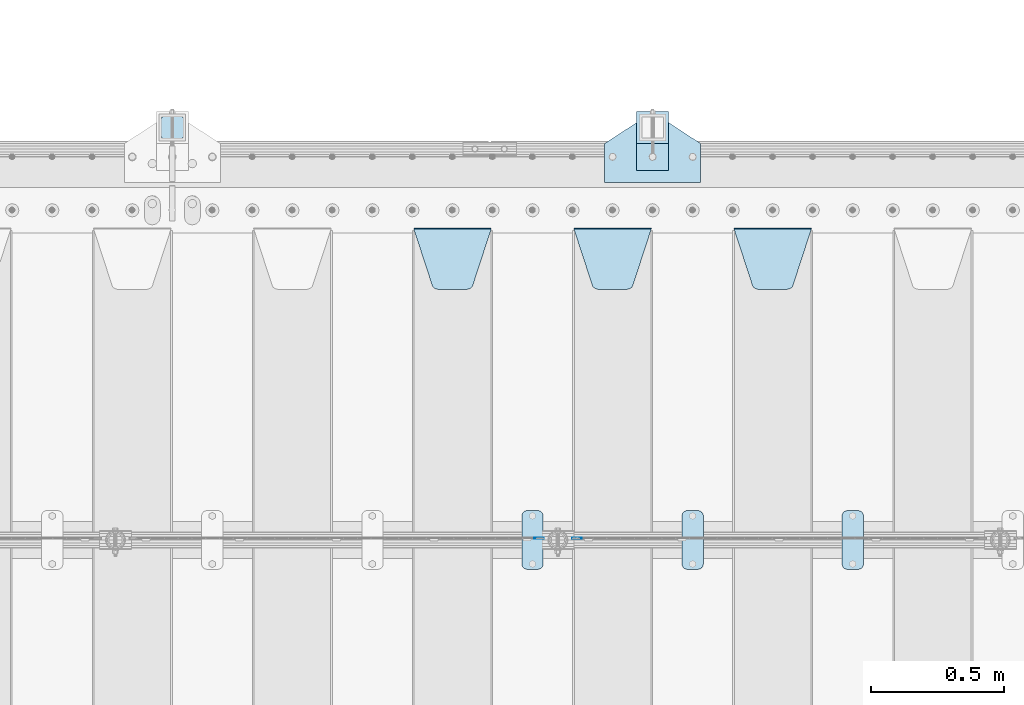
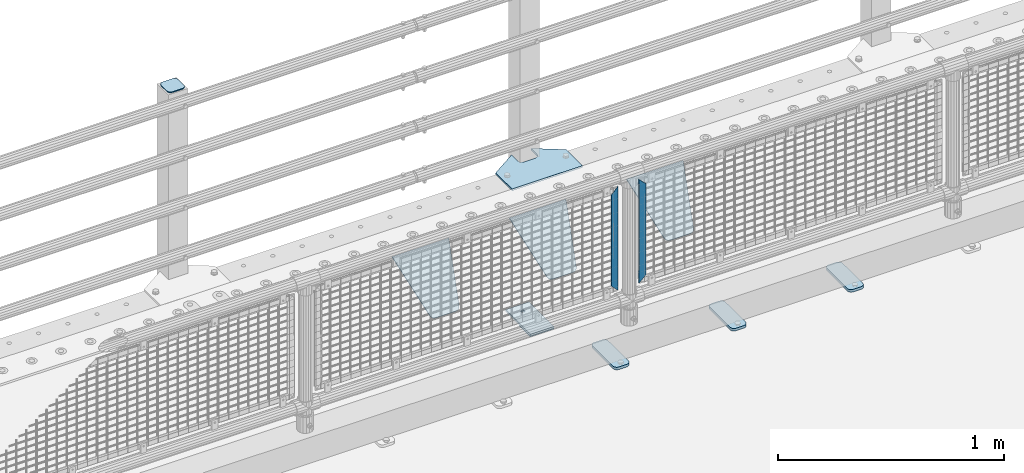
# One storey, part 197 of 219: 12 plates.
"""IFC2X3 building model written with IfcOpenShell, lengths in millimetres."""

import ifcopenshell
import ifcopenshell.guid

model = None  # the IFC model being written
_history = None  # IfcOwnerHistory: only IFC2X3 demands one
_inside = {}  # id of a spatial element -> (the spatial element, [elements in it])
_under = {}  # id of a project, library or spatial element -> (it, [spatial elements below it])
_declared = {}  # id of a project -> (the project, [libraries it declares])
_typed = {}  # id of a type object -> (the type object, [elements of that type])
_made_of = {}  # id of a material, layer set ... -> (it, [elements and type objects made of it])


def new_model(schema):
    """Start an empty IFC model of exactly this schema.

    Asked for "IFC4X3", IfcOpenShell would pick the latest addendum, in which some entities
    have other attributes; the version numbers below select the first issue.
    IFC2X3 requires an IfcOwnerHistory on every rooted entity: one is made here for all.
    """
    global model, _history
    if schema == "IFC4X3":
        model = ifcopenshell.file(schema_version=(4, 3, 0, 0))
    else:
        model = ifcopenshell.file(schema=schema)
    _inside.clear()
    _under.clear()
    _declared.clear()
    _typed.clear()
    _made_of.clear()
    _history = None
    if model.schema == "IFC2X3":
        org = make("IfcOrganization", Name="unknown")
        user = make(
            "IfcPersonAndOrganization",
            ThePerson=make("IfcPerson", FamilyName="unknown"),
            TheOrganization=org,
        )
        app = make(
            "IfcApplication",
            ApplicationDeveloper=org,
            Version="unknown",
            ApplicationFullName="unknown",
            ApplicationIdentifier="unknown",
        )
        _history = make(
            "IfcOwnerHistory",
            OwningUser=user,
            OwningApplication=app,
            ChangeAction="ADDED",
            CreationDate=0,
        )
    return model


def make(cls, **values):
    """One entity of the class cls with the attributes given. An attribute that is None is left unset."""
    return model.create_entity(
        cls, **{name: value for name, value in values.items() if value is not None}
    )


def rooted(cls, **values):
    """An entity with a GlobalId (a new one), such as an element, a storey or a relation."""
    return make(cls, GlobalId=ifcopenshell.guid.new(), OwnerHistory=_history, **values)


def si_unit(unit_type, name, prefix=None):
    """IfcSIUnit, for example si_unit("LENGTHUNIT", "METRE", prefix="MILLI")."""
    return make("IfcSIUnit", UnitType=unit_type, Prefix=prefix, Name=name)


def assignment(units):
    """IfcUnitAssignment: the units of a project."""
    return None if units is None else make("IfcUnitAssignment", Units=units)


def point(xyz):
    """IfcCartesianPoint."""
    return None if xyz is None else make("IfcCartesianPoint", Coordinates=xyz)


def direction(xyz):
    """IfcDirection."""
    return None if xyz is None else make("IfcDirection", DirectionRatios=xyz)


def frame(location, z_axis=None, x_axis=None):
    """IfcAxis2Placement3D, a coordinate frame: its origin and axes. An axis left out is left unset."""
    return make(
        "IfcAxis2Placement3D",
        Location=point(location),
        Axis=direction(z_axis),
        RefDirection=direction(x_axis),
    )


def origin_with_axes():
    """The frame at (0, 0, 0) with the z axis (0, 0, 1) and the x axis (1, 0, 0) written out."""
    return frame((0.0, 0.0, 0.0), z_axis=(0.0, 0.0, 1.0), x_axis=(1.0, 0.0, 0.0))


def place(relative_to, where):
    """IfcLocalPlacement: puts the frame where relative to a parent placement (None: the world)."""
    return make(
        "IfcLocalPlacement", PlacementRelTo=relative_to, RelativePlacement=where
    )


def context(
    kind, dimensions, precision=None, world=None, true_north=None, identifier=None
):
    """IfcGeometricRepresentationContext, for example the 3D "Model" context."""
    return make(
        "IfcGeometricRepresentationContext",
        ContextIdentifier=identifier,
        ContextType=kind,
        CoordinateSpaceDimension=dimensions,
        Precision=precision,
        WorldCoordinateSystem=world,
        TrueNorth=true_north,
    )


def subcontext(parent, identifier, kind, view, scale=None):
    """IfcGeometricRepresentationSubContext, for example "Body" below "Model"."""
    return make(
        "IfcGeometricRepresentationSubContext",
        ContextIdentifier=identifier,
        ContextType=kind,
        ParentContext=parent,
        TargetScale=scale,
        TargetView=view,
    )


def project(units=None, contexts=None):
    """IfcProject with its units and contexts."""
    return rooted(
        "IfcProject",
        Name="project",
        RepresentationContexts=contexts,
        UnitsInContext=assignment(units),
    )


def spatial(cls, under=None, at=None, **own):
    """A site, building, storey or space (cls), placed at a placement, below another one or the project."""
    s = rooted(cls, ObjectPlacement=at, **own)
    if under is not None:
        _under.setdefault(under.id(), (under, []))[1].append(s)
    return s


def faces_of(points, faces, orient=None, outer=None):
    """IfcFace entities. A face is a list of loops; a loop is a list of indices into points, from 0.

    orient and outer hold one flag for each loop. By default every Orientation is true, the
    first loop of a face is its IfcFaceOuterBound and the others are IfcFaceBound.
    """
    made = []
    for i, loops in enumerate(faces):
        bounds = []
        for j, loop in enumerate(loops):
            is_outer = j == 0 if outer is None else outer[i][j]
            bounds.append(
                make(
                    "IfcFaceOuterBound" if is_outer else "IfcFaceBound",
                    Bound=make("IfcPolyLoop", Polygon=[points[k] for k in loop]),
                    Orientation=True if orient is None else orient[i][j],
                )
            )
        made.append(make("IfcFace", Bounds=bounds))
    return made


def faceted_brep(points, faces, orient=None, outer=None, voids=None):
    """IfcFacetedBrep: a solid bounded by flat faces; with voids (closed shells), ...WithVoids."""
    shared = [point(p) for p in points]
    hull = make("IfcClosedShell", CfsFaces=faces_of(shared, faces, orient, outer))
    if voids is None:
        return make("IfcFacetedBrep", Outer=hull)
    return make(
        "IfcFacetedBrepWithVoids",
        Outer=hull,
        Voids=[
            make(cls, CfsFaces=faces_of(shared, fs, o, b)) for cls, fs, o, b in voids
        ],
    )


def shape(context_of_items, identifier, shape_type, items):
    """IfcShapeRepresentation: the items that make up one representation, for example the "Body"."""
    return make(
        "IfcShapeRepresentation",
        ContextOfItems=context_of_items,
        RepresentationIdentifier=identifier,
        RepresentationType=shape_type,
        Items=items,
    )


def material(Name=None, Category=None):
    """IfcMaterial."""
    return make("IfcMaterial", Name=Name, Category=Category)


def made_of(thing, what):
    """Note that an element or type object is made of a material, layer set ...; save() writes the relation."""
    if what is not None:
        _made_of.setdefault(what.id(), (what, []))[1].append(thing)
    return thing


def type_object(cls, material=None, **own):
    """A type object (cls), such as IfcWallType, which elements share."""
    return made_of(rooted(cls, **own), material)


def element(
    cls,
    number,
    at=None,
    inside=None,
    cuts=None,
    type_object=None,
    material=None,
    context=None,
    identifier="Body",
    shape_type=None,
    held_by="IfcProductDefinitionShape",
    body=None,
    shapes=None,
    **own,
):
    """One element of the class cls, such as IfcWall. Its Tag is "e" and its number.

    at: its placement. inside: the storey or other place that contains it. cuts: it is an
    opening in that element (IfcRelVoidsElement). A single representation is given by context,
    identifier, shape_type and body (its items); several are given by shapes. held_by: the class
    of the entity that holds the representations. save() writes the other relations.
    """
    e = rooted(cls, Tag="e%d" % number, ObjectPlacement=at, **own)
    if body is not None:
        shapes = [shape(context, identifier, shape_type, body)]
    if shapes is not None:
        e.Representation = make(held_by, Representations=shapes)
    if inside is not None:
        _inside.setdefault(inside.id(), (inside, []))[1].append(e)
    if cuts is not None:
        rooted(
            "IfcRelVoidsElement", RelatingBuildingElement=cuts, RelatedOpeningElement=e
        )
    if type_object is not None:
        _typed.setdefault(type_object.id(), (type_object, []))[1].append(e)
    return made_of(e, material)


def aggregate(whole, parts):
    """IfcRelAggregates: a whole, such as a stair, and the parts it consists of."""
    return rooted("IfcRelAggregates", RelatingObject=whole, RelatedObjects=parts)


def save(model, path):
    """Write the relations noted so far, then the file.

    IfcRelAggregates (storeys below a building ...), IfcRelContainedInSpatialStructure (elements
    in a storey), IfcRelDefinesByType, IfcRelAssociatesMaterial and IfcRelDeclares: one each for
    every whole, place, type object, material and project.
    """
    for whole, parts in _under.values():
        aggregate(whole, parts)
    for where, things in _inside.values():
        rooted(
            "IfcRelContainedInSpatialStructure",
            RelatedElements=things,
            RelatingStructure=where,
        )
    for kind, things in _typed.values():
        rooted("IfcRelDefinesByType", RelatedObjects=things, RelatingType=kind)
    for what, things in _made_of.values():
        rooted("IfcRelAssociatesMaterial", RelatedObjects=things, RelatingMaterial=what)
    for by, libraries in _declared.values():
        rooted("IfcRelDeclares", RelatingContext=by, RelatedDefinitions=libraries)
    model.write(path)


model = new_model("IFC2X3")

# Units and contexts
model_context = context("Model", 3, precision=1e-05, world=origin_with_axes())
body_context = subcontext(model_context, "Body", "Model", "MODEL_VIEW")
ifc_project = project(units=[si_unit("LENGTHUNIT", "METRE", prefix="MILLI"), si_unit("AREAUNIT", "SQUARE_METRE"), si_unit("VOLUMEUNIT", "CUBIC_METRE"), si_unit("MASSUNIT", "GRAM", prefix="KILO"), si_unit("TIMEUNIT", "SECOND"), si_unit("PLANEANGLEUNIT", "RADIAN"), si_unit("SOLIDANGLEUNIT", "STERADIAN"), si_unit("THERMODYNAMICTEMPERATUREUNIT", "DEGREE_CELSIUS"), si_unit("LUMINOUSINTENSITYUNIT", "LUMEN")], contexts=[model_context])

# Site, building, storey
site_placement = place(None, origin_with_axes())
site = spatial("IfcSite", under=ifc_project, at=site_placement, CompositionType="ELEMENT")
building_placement = place(site_placement, origin_with_axes())
building = spatial("IfcBuilding", under=site, at=building_placement, Name="Standard", CompositionType="ELEMENT")
storey_placement = place(building_placement, origin_with_axes())
storey = spatial("IfcBuildingStorey", under=building, at=storey_placement, Name="Undefined", CompositionType="ELEMENT", Elevation=0.0)

# Plates
ifc_material_1 = material(Name="STEEL/S355N")
plate_type_1 = type_object("IfcPlateType", PredefinedType="NOTDEFINED")
plate_1_placement = place(storey_placement, frame((6255.0, 32831.767766956, -1.76776695296758), z_axis=(0.0, -0.707106781186547, -0.707106781186548), x_axis=(1.0, 0.0, 0.0)))
element("IfcPlate", 1, at=plate_1_placement, inside=storey, type_object=plate_type_1, material=ifc_material_1, context=body_context, shape_type="Brep", body=[
    faceted_brep([(0.0, -2.5, 0.0), (69.345504679477, -2.5, 300.171731424834), (69.345504679477, 2.49999999999636, 300.171731424831), (0.0, 2.5, 0.0), (70.9274061199576, -2.50000000000364, 304.8974424154), (70.9274061199576, 2.49999999999636, 304.8974424154), (73.3818627772307, -2.50000000000364, 309.234538108532), (73.3818627772307, 2.49999999999636, 309.234538108532), (76.6187032999569, -2.50000000000364, 313.023683126106), (76.6187032999569, 2.49999999999636, 313.023683126106), (80.5190132704993, -2.50000000000364, 316.125672595372), (80.5190132704993, 2.49999999999636, 316.125672595372), (84.9395038596831, -2.50000000000364, 318.426546230476), (84.9395038596831, 2.5, 318.426546230479), (89.7177759439237, -2.50000000000364, 319.841774983277), (89.7177759439237, 2.5, 319.841774983281), (94.6782862926502, -2.50000000000364, 320.319366455078), (94.6782862926502, 2.49999999999636, 320.319366455078), (195.32171370735, -2.50000000000364, 320.319366455078), (195.32171370735, 2.49999999999636, 320.319366455078), (200.282224056076, -2.50000000000364, 319.841774983277), (200.282224056076, 2.5, 319.841774983281), (205.060496140317, -2.50000000000364, 318.426546230476), (205.060496140317, 2.49999999999636, 318.426546230476), (209.480986729501, -2.50000000000364, 316.125672595372), (209.480986729501, 2.49999999999636, 316.125672595372), (213.381296700043, -2.50000000000364, 313.023683126106), (213.381296700043, 2.49999999999272, 313.023683126106), (216.618137222769, -2.50000000000364, 309.234538108529), (216.618137222769, 2.49999999999636, 309.234538108525), (219.072593880042, -2.50000000000364, 304.8974424154), (219.072593880042, 2.49999999999636, 304.8974424154), (220.654495320523, -2.5, 300.171731424834), (220.654495320523, 2.49999999999636, 300.171731424831), (290.0, -2.50000000000364, 3.63797880709171e-12), (290.0, 2.49999999999636, 0.0)], [[[0, 1, 2, 3]], [[1, 4, 5, 2]], [[4, 6, 7, 5]], [[6, 8, 9, 7]], [[8, 10, 11, 9]], [[10, 12, 13, 11]], [[12, 14, 15, 13]], [[14, 16, 17, 15]], [[16, 18, 19, 17]], [[18, 20, 21, 19]], [[20, 22, 23, 21]], [[22, 24, 25, 23]], [[24, 26, 27, 25]], [[26, 28, 29, 27]], [[28, 30, 31, 29]], [[30, 32, 33, 31]], [[32, 34, 35, 33]], [[34, 0, 3, 35]], [[5, 7, 9, 11, 13, 15, 17, 19, 21, 23, 25, 27, 29, 31, 33, 35, 3, 2]], [[34, 32, 30, 28, 26, 24, 22, 20, 18, 16, 14, 12, 10, 8, 6, 4, 1, 0]]]),
])
plate_2_placement = place(storey_placement, frame((5655.0, 32831.767766956, -1.76776695296758), z_axis=(0.0, -0.707106781186547, -0.707106781186548), x_axis=(1.0, 0.0, 0.0)))
element("IfcPlate", 2, at=plate_2_placement, inside=storey, type_object=plate_type_1, material=ifc_material_1, context=body_context, shape_type="Brep", body=[
    faceted_brep([(0.0, -2.5, 0.0), (69.345504679477, -2.5, 300.171731424834), (69.345504679477, 2.49999999999636, 300.171731424831), (0.0, 2.5, 0.0), (70.9274061199576, -2.50000000000364, 304.8974424154), (70.9274061199576, 2.49999999999636, 304.8974424154), (73.3818627772307, -2.50000000000364, 309.234538108532), (73.3818627772307, 2.49999999999636, 309.234538108532), (76.6187032999569, -2.50000000000364, 313.023683126106), (76.6187032999569, 2.49999999999636, 313.023683126106), (80.5190132704993, -2.50000000000364, 316.125672595372), (80.5190132704993, 2.49999999999636, 316.125672595372), (84.9395038596831, -2.50000000000364, 318.426546230476), (84.9395038596831, 2.5, 318.426546230479), (89.7177759439237, -2.50000000000364, 319.841774983277), (89.7177759439237, 2.5, 319.841774983281), (94.6782862926502, -2.50000000000364, 320.319366455078), (94.6782862926502, 2.49999999999636, 320.319366455078), (195.32171370735, -2.50000000000364, 320.319366455078), (195.32171370735, 2.49999999999636, 320.319366455078), (200.282224056076, -2.50000000000364, 319.841774983277), (200.282224056076, 2.5, 319.841774983281), (205.060496140317, -2.50000000000364, 318.426546230476), (205.060496140317, 2.49999999999636, 318.426546230476), (209.480986729501, -2.50000000000364, 316.125672595372), (209.480986729501, 2.49999999999636, 316.125672595372), (213.381296700043, -2.50000000000364, 313.023683126106), (213.381296700043, 2.49999999999272, 313.023683126106), (216.618137222769, -2.50000000000364, 309.234538108529), (216.618137222769, 2.49999999999636, 309.234538108525), (219.072593880042, -2.50000000000364, 304.8974424154), (219.072593880042, 2.49999999999636, 304.8974424154), (220.654495320523, -2.5, 300.171731424834), (220.654495320523, 2.49999999999636, 300.171731424831), (290.0, -2.50000000000364, 3.63797880709171e-12), (290.0, 2.49999999999636, 0.0)], [[[0, 1, 2, 3]], [[1, 4, 5, 2]], [[4, 6, 7, 5]], [[6, 8, 9, 7]], [[8, 10, 11, 9]], [[10, 12, 13, 11]], [[12, 14, 15, 13]], [[14, 16, 17, 15]], [[16, 18, 19, 17]], [[18, 20, 21, 19]], [[20, 22, 23, 21]], [[22, 24, 25, 23]], [[24, 26, 27, 25]], [[26, 28, 29, 27]], [[28, 30, 31, 29]], [[30, 32, 33, 31]], [[32, 34, 35, 33]], [[34, 0, 3, 35]], [[5, 7, 9, 11, 13, 15, 17, 19, 21, 23, 25, 27, 29, 31, 33, 35, 3, 2]], [[34, 32, 30, 28, 26, 24, 22, 20, 18, 16, 14, 12, 10, 8, 6, 4, 1, 0]]]),
])
plate_3_placement = place(storey_placement, frame((5055.0, 32831.767766956, -1.76776695296758), z_axis=(0.0, -0.707106781186547, -0.707106781186548), x_axis=(1.0, 0.0, 0.0)))
element("IfcPlate", 3, at=plate_3_placement, inside=storey, type_object=plate_type_1, material=ifc_material_1, context=body_context, shape_type="Brep", body=[
    faceted_brep([(0.0, -2.5, 0.0), (69.345504679477, -2.5, 300.171731424834), (69.345504679477, 2.49999999999636, 300.171731424831), (0.0, 2.5, 0.0), (70.9274061199576, -2.50000000000364, 304.8974424154), (70.9274061199576, 2.49999999999636, 304.8974424154), (73.3818627772307, -2.50000000000364, 309.234538108532), (73.3818627772307, 2.49999999999636, 309.234538108532), (76.6187032999569, -2.50000000000364, 313.023683126106), (76.6187032999569, 2.49999999999636, 313.023683126106), (80.5190132704993, -2.50000000000364, 316.125672595372), (80.5190132704993, 2.49999999999636, 316.125672595372), (84.9395038596831, -2.50000000000364, 318.426546230476), (84.9395038596831, 2.5, 318.426546230479), (89.7177759439237, -2.50000000000364, 319.841774983277), (89.7177759439237, 2.5, 319.841774983281), (94.6782862926502, -2.50000000000364, 320.319366455078), (94.6782862926502, 2.49999999999636, 320.319366455078), (195.32171370735, -2.50000000000364, 320.319366455078), (195.32171370735, 2.49999999999636, 320.319366455078), (200.282224056076, -2.50000000000364, 319.841774983277), (200.282224056076, 2.5, 319.841774983281), (205.060496140317, -2.50000000000364, 318.426546230476), (205.060496140317, 2.49999999999636, 318.426546230476), (209.480986729501, -2.50000000000364, 316.125672595372), (209.480986729501, 2.49999999999636, 316.125672595372), (213.381296700043, -2.50000000000364, 313.023683126106), (213.381296700043, 2.49999999999272, 313.023683126106), (216.618137222769, -2.50000000000364, 309.234538108529), (216.618137222769, 2.49999999999636, 309.234538108525), (219.072593880042, -2.50000000000364, 304.8974424154), (219.072593880042, 2.49999999999636, 304.8974424154), (220.654495320523, -2.5, 300.171731424834), (220.654495320523, 2.49999999999636, 300.171731424831), (290.0, -2.50000000000364, 3.63797880709171e-12), (290.0, 2.49999999999636, 0.0)], [[[0, 1, 2, 3]], [[1, 4, 5, 2]], [[4, 6, 7, 5]], [[6, 8, 9, 7]], [[8, 10, 11, 9]], [[10, 12, 13, 11]], [[12, 14, 15, 13]], [[14, 16, 17, 15]], [[16, 18, 19, 17]], [[18, 20, 21, 19]], [[20, 22, 23, 21]], [[22, 24, 25, 23]], [[24, 26, 27, 25]], [[26, 28, 29, 27]], [[28, 30, 31, 29]], [[30, 32, 33, 31]], [[32, 34, 35, 33]], [[34, 0, 3, 35]], [[5, 7, 9, 11, 13, 15, 17, 19, 21, 23, 25, 27, 29, 31, 33, 35, 3, 2]], [[34, 32, 30, 28, 26, 24, 22, 20, 18, 16, 14, 12, 10, 8, 6, 4, 1, 0]]]),
])
ifc_material_2 = material(Name="Misc_Undefined")
plate_type_2 = type_object("IfcPlateType", PredefinedType="NOTDEFINED")
plate_4_placement = place(storey_placement, frame((5683.50971354097, 31670.5, 879.519963133601), z_axis=(-0.707008801899319, 0.0, -0.707204746899291), x_axis=(-0.707204746899285, 0.0, 0.707008801899324)))
element("IfcPlate", 4, at=plate_4_placement, inside=storey, type_object=plate_type_2, material=ifc_material_2, context=body_context, shape_type="Brep", body=[
    faceted_brep([(0.0, -1.5, -5.6843418860808e-14), (-348.552185058593, -1.5, 348.655029296875), (-348.552185058593, 1.5, 348.655029296875), (0.0, 1.5, -5.6843418860808e-14), (-348.544891357421, -1.5, 398.152496337892), (-348.544891357421, 1.5, 398.152496337892), (49.5043945312482, -1.5, 7.6397554948926e-11), (49.5043945312482, 1.5, 7.6397554948926e-11)], [[[0, 1, 2, 3]], [[1, 4, 5, 2]], [[4, 6, 7, 5]], [[6, 0, 3, 7]], [[5, 7, 3, 2]], [[6, 4, 1, 0]]]),
])
plate_5_placement = place(storey_placement, frame((5506.49968748361, 31670.5, 879.52), z_axis=(0.707103624179499, 0.0, -0.707109938179501), x_axis=(0.707109938179499, 0.0, 0.707103624179502)))
element("IfcPlate", 5, at=plate_5_placement, inside=storey, type_object=plate_type_2, material=ifc_material_2, context=body_context, shape_type="Brep", body=[
    faceted_brep([(0.0, -1.5, -5.6843418860808e-14), (-348.605163574219, -1.5, 348.602081298829), (-348.605163574219, 1.5, 348.602081298829), (0.0, 1.5, -5.6843418860808e-14), (-348.605163574217, -1.5, 398.0993347168), (-348.605163574217, 1.5, 398.0993347168), (49.4976959228516, -1.5, -1.0550138540566e-10), (49.4976959228516, 1.5, -1.0550138540566e-10)], [[[0, 1, 2, 3]], [[1, 4, 5, 2]], [[4, 6, 7, 5]], [[6, 0, 3, 7]], [[5, 7, 3, 2]], [[6, 4, 1, 0]]]),
])
ifc_material_3 = material(Name="STEEL/S355J2")
plate_type_3 = type_object("IfcPlateType", PredefinedType="NOTDEFINED")
plate_6_placement = place(storey_placement, frame((6660.0, 31774.5, 21.0199999999977), z_axis=(1.0, 0.0, 0.0), x_axis=(0.0, -1.0, 0.0)))
element("IfcPlate", 6, at=plate_6_placement, inside=storey, type_object=plate_type_3, material=ifc_material_3, context=body_context, shape_type="Brep", body=[
    faceted_brep([(0.0, -7.0, 20.0), (0.0, -7.0, 60.0), (0.0, 7.0, 60.0), (0.0, 7.0, 20.0), (0.384294391937146, -7.0, 63.9018064403226), (0.384294391937146, 7.0, 63.9018064403226), (1.52240934977453, -7.0, 67.6536686473009), (1.52240934977453, 7.0, 67.6536686473009), (3.37060775395003, -7.0, 71.1114046603925), (3.37060775395003, 7.0, 71.1114046603925), (5.8578643762703, -7.0, 74.1421356237315), (5.8578643762703, 7.0, 74.1421356237315), (8.88859533960931, -7.0, 76.6293922460518), (8.88859533960931, 7.0, 76.6293922460518), (12.3463313526991, -7.0, 78.4775906502255), (12.3463313526991, 7.0, 78.4775906502255), (16.0981935596792, -7.0, 79.6157056080647), (16.0981935596792, 7.0, 79.6157056080647), (20.0, -7.0, 80.0), (20.0, 7.0, 80.0), (200.0, -7.0, 80.0), (200.0, 7.0, 80.0), (203.901806440321, -7.0, 79.6157056080647), (203.901806440321, 7.0, 79.6157056080647), (207.653668647301, -7.0, 78.4775906502255), (207.653668647301, 7.0, 78.4775906502255), (211.111404660391, -7.0, 76.6293922460518), (211.111404660391, 7.0, 76.6293922460518), (214.14213562373, -7.0, 74.1421356237315), (214.14213562373, 7.0, 74.1421356237315), (216.62939224605, -7.0, 71.1114046603925), (216.62939224605, 7.0, 71.1114046603925), (218.477590650225, -7.0, 67.6536686473009), (218.477590650225, 7.0, 67.6536686473009), (219.615705608063, -7.0, 63.9018064403226), (219.615705608063, 7.0, 63.9018064403226), (220.0, -7.0, 60.0), (220.0, 7.0, 60.0), (220.0, -7.0, 20.0), (220.0, 7.0, 20.0), (219.615705608063, -7.0, 16.0981935596774), (219.615705608063, 7.0, 16.0981935596774), (218.477590650225, -7.0, 12.3463313526991), (218.477590650225, 7.0, 12.3463313526991), (216.62939224605, -7.0, 8.88859533960749), (216.62939224605, 7.0, 8.88859533960749), (214.14213562373, -7.0, 5.85786437626848), (214.14213562373, 7.0, 5.85786437626848), (211.111404660391, -7.0, 3.37060775394821), (211.111404660391, 7.0, 3.37060775394821), (207.653668647301, -7.0, 1.52240934977453), (207.653668647301, 7.0, 1.52240934977453), (203.901806440321, -7.0, 0.384294391935327), (203.901806440321, 7.0, 0.384294391935327), (200.0, -7.0, 0.0), (200.0, 7.0, 0.0), (20.0, -7.0, 0.0), (20.0, 7.0, 0.0), (16.0981935596792, -7.0, 0.384294391935327), (16.0981935596792, 7.0, 0.384294391935327), (12.3463313526991, -7.0, 1.52240934977453), (12.3463313526991, 7.0, 1.52240934977453), (8.88859533960931, -7.0, 3.37060775394821), (8.88859533960931, 7.0, 3.37060775394821), (5.8578643762703, -7.0, 5.85786437626848), (5.8578643762703, 7.0, 5.85786437626848), (3.37060775395003, -7.0, 8.88859533960749), (3.37060775395003, 7.0, 8.88859533960749), (1.52240934977453, -7.0, 12.3463313526991), (1.52240934977453, 7.0, 12.3463313526991), (0.384294391937146, -7.0, 16.0981935596774), (0.384294391937146, 7.0, 16.0981935596774)], [[[0, 1, 2, 3]], [[1, 4, 5, 2]], [[4, 6, 7, 5]], [[6, 8, 9, 7]], [[8, 10, 11, 9]], [[10, 12, 13, 11]], [[12, 14, 15, 13]], [[14, 16, 17, 15]], [[16, 18, 19, 17]], [[18, 20, 21, 19]], [[20, 22, 23, 21]], [[22, 24, 25, 23]], [[24, 26, 27, 25]], [[26, 28, 29, 27]], [[28, 30, 31, 29]], [[30, 32, 33, 31]], [[32, 34, 35, 33]], [[34, 36, 37, 35]], [[36, 38, 39, 37]], [[38, 40, 41, 39]], [[40, 42, 43, 41]], [[42, 44, 45, 43]], [[44, 46, 47, 45]], [[46, 48, 49, 47]], [[48, 50, 51, 49]], [[50, 52, 53, 51]], [[52, 54, 55, 53]], [[54, 56, 57, 55]], [[56, 58, 59, 57]], [[58, 60, 61, 59]], [[60, 62, 63, 61]], [[62, 64, 65, 63]], [[64, 66, 67, 65]], [[66, 68, 69, 67]], [[68, 70, 71, 69]], [[70, 0, 3, 71]], [[5, 7, 9, 11, 13, 15, 17, 19, 21, 23, 25, 27, 29, 31, 33, 35, 37, 39, 41, 43, 45, 47, 49, 51, 53, 55, 57, 59, 61, 63, 65, 67, 69, 71, 3, 2]], [[70, 68, 66, 64, 62, 60, 58, 56, 54, 52, 50, 48, 46, 44, 42, 40, 38, 36, 34, 32, 30, 28, 26, 24, 22, 20, 18, 16, 14, 12, 10, 8, 6, 4, 1, 0]]]),
])
plate_7_placement = place(storey_placement, frame((6060.0, 31774.5, 21.0199999999977), z_axis=(1.0, 0.0, 0.0), x_axis=(0.0, -1.0, 0.0)))
element("IfcPlate", 7, at=plate_7_placement, inside=storey, type_object=plate_type_3, material=ifc_material_3, context=body_context, shape_type="Brep", body=[
    faceted_brep([(0.0, -7.0, 20.0), (0.0, -7.0, 60.0), (0.0, 7.0, 60.0), (0.0, 7.0, 20.0), (0.384294391937146, -7.0, 63.9018064403226), (0.384294391937146, 7.0, 63.9018064403226), (1.52240934977453, -7.0, 67.6536686473009), (1.52240934977453, 7.0, 67.6536686473009), (3.37060775395003, -7.0, 71.1114046603925), (3.37060775395003, 7.0, 71.1114046603925), (5.8578643762703, -7.0, 74.1421356237315), (5.8578643762703, 7.0, 74.1421356237315), (8.88859533960931, -7.0, 76.6293922460518), (8.88859533960931, 7.0, 76.6293922460518), (12.3463313526991, -7.0, 78.4775906502255), (12.3463313526991, 7.0, 78.4775906502255), (16.0981935596792, -7.0, 79.6157056080647), (16.0981935596792, 7.0, 79.6157056080647), (20.0, -7.0, 80.0), (20.0, 7.0, 80.0), (200.0, -7.0, 80.0), (200.0, 7.0, 80.0), (203.901806440321, -7.0, 79.6157056080647), (203.901806440321, 7.0, 79.6157056080647), (207.653668647301, -7.0, 78.4775906502255), (207.653668647301, 7.0, 78.4775906502255), (211.111404660391, -7.0, 76.6293922460518), (211.111404660391, 7.0, 76.6293922460518), (214.14213562373, -7.0, 74.1421356237315), (214.14213562373, 7.0, 74.1421356237315), (216.62939224605, -7.0, 71.1114046603925), (216.62939224605, 7.0, 71.1114046603925), (218.477590650225, -7.0, 67.6536686473009), (218.477590650225, 7.0, 67.6536686473009), (219.615705608063, -7.0, 63.9018064403226), (219.615705608063, 7.0, 63.9018064403226), (220.0, -7.0, 60.0), (220.0, 7.0, 60.0), (220.0, -7.0, 20.0), (220.0, 7.0, 20.0), (219.615705608063, -7.0, 16.0981935596774), (219.615705608063, 7.0, 16.0981935596774), (218.477590650225, -7.0, 12.3463313526991), (218.477590650225, 7.0, 12.3463313526991), (216.62939224605, -7.0, 8.88859533960749), (216.62939224605, 7.0, 8.88859533960749), (214.14213562373, -7.0, 5.85786437626848), (214.14213562373, 7.0, 5.85786437626848), (211.111404660391, -7.0, 3.37060775394821), (211.111404660391, 7.0, 3.37060775394821), (207.653668647301, -7.0, 1.52240934977453), (207.653668647301, 7.0, 1.52240934977453), (203.901806440321, -7.0, 0.384294391935327), (203.901806440321, 7.0, 0.384294391935327), (200.0, -7.0, 0.0), (200.0, 7.0, 0.0), (20.0, -7.0, 0.0), (20.0, 7.0, 0.0), (16.0981935596792, -7.0, 0.384294391935327), (16.0981935596792, 7.0, 0.384294391935327), (12.3463313526991, -7.0, 1.52240934977453), (12.3463313526991, 7.0, 1.52240934977453), (8.88859533960931, -7.0, 3.37060775394821), (8.88859533960931, 7.0, 3.37060775394821), (5.8578643762703, -7.0, 5.85786437626848), (5.8578643762703, 7.0, 5.85786437626848), (3.37060775395003, -7.0, 8.88859533960749), (3.37060775395003, 7.0, 8.88859533960749), (1.52240934977453, -7.0, 12.3463313526991), (1.52240934977453, 7.0, 12.3463313526991), (0.384294391937146, -7.0, 16.0981935596774), (0.384294391937146, 7.0, 16.0981935596774)], [[[0, 1, 2, 3]], [[1, 4, 5, 2]], [[4, 6, 7, 5]], [[6, 8, 9, 7]], [[8, 10, 11, 9]], [[10, 12, 13, 11]], [[12, 14, 15, 13]], [[14, 16, 17, 15]], [[16, 18, 19, 17]], [[18, 20, 21, 19]], [[20, 22, 23, 21]], [[22, 24, 25, 23]], [[24, 26, 27, 25]], [[26, 28, 29, 27]], [[28, 30, 31, 29]], [[30, 32, 33, 31]], [[32, 34, 35, 33]], [[34, 36, 37, 35]], [[36, 38, 39, 37]], [[38, 40, 41, 39]], [[40, 42, 43, 41]], [[42, 44, 45, 43]], [[44, 46, 47, 45]], [[46, 48, 49, 47]], [[48, 50, 51, 49]], [[50, 52, 53, 51]], [[52, 54, 55, 53]], [[54, 56, 57, 55]], [[56, 58, 59, 57]], [[58, 60, 61, 59]], [[60, 62, 63, 61]], [[62, 64, 65, 63]], [[64, 66, 67, 65]], [[66, 68, 69, 67]], [[68, 70, 71, 69]], [[70, 0, 3, 71]], [[5, 7, 9, 11, 13, 15, 17, 19, 21, 23, 25, 27, 29, 31, 33, 35, 37, 39, 41, 43, 45, 47, 49, 51, 53, 55, 57, 59, 61, 63, 65, 67, 69, 71, 3, 2]], [[70, 68, 66, 64, 62, 60, 58, 56, 54, 52, 50, 48, 46, 44, 42, 40, 38, 36, 34, 32, 30, 28, 26, 24, 22, 20, 18, 16, 14, 12, 10, 8, 6, 4, 1, 0]]]),
])
plate_8_placement = place(storey_placement, frame((5460.0, 31774.5, 21.0199999999977), z_axis=(1.0, 0.0, 0.0), x_axis=(0.0, -1.0, 0.0)))
element("IfcPlate", 8, at=plate_8_placement, inside=storey, type_object=plate_type_3, material=ifc_material_3, context=body_context, shape_type="Brep", body=[
    faceted_brep([(0.0, -7.0, 20.0), (0.0, -7.0, 60.0), (0.0, 7.0, 60.0), (0.0, 7.0, 20.0), (0.384294391937146, -7.0, 63.9018064403226), (0.384294391937146, 7.0, 63.9018064403226), (1.52240934977453, -7.0, 67.6536686473009), (1.52240934977453, 7.0, 67.6536686473009), (3.37060775395003, -7.0, 71.1114046603925), (3.37060775395003, 7.0, 71.1114046603925), (5.8578643762703, -7.0, 74.1421356237315), (5.8578643762703, 7.0, 74.1421356237315), (8.88859533960931, -7.0, 76.6293922460518), (8.88859533960931, 7.0, 76.6293922460518), (12.3463313526991, -7.0, 78.4775906502255), (12.3463313526991, 7.0, 78.4775906502255), (16.0981935596792, -7.0, 79.6157056080647), (16.0981935596792, 7.0, 79.6157056080647), (20.0, -7.0, 80.0), (20.0, 7.0, 80.0), (200.0, -7.0, 80.0), (200.0, 7.0, 80.0), (203.901806440321, -7.0, 79.6157056080647), (203.901806440321, 7.0, 79.6157056080647), (207.653668647301, -7.0, 78.4775906502255), (207.653668647301, 7.0, 78.4775906502255), (211.111404660391, -7.0, 76.6293922460518), (211.111404660391, 7.0, 76.6293922460518), (214.14213562373, -7.0, 74.1421356237315), (214.14213562373, 7.0, 74.1421356237315), (216.62939224605, -7.0, 71.1114046603925), (216.62939224605, 7.0, 71.1114046603925), (218.477590650225, -7.0, 67.6536686473009), (218.477590650225, 7.0, 67.6536686473009), (219.615705608063, -7.0, 63.9018064403226), (219.615705608063, 7.0, 63.9018064403226), (220.0, -7.0, 60.0), (220.0, 7.0, 60.0), (220.0, -7.0, 20.0), (220.0, 7.0, 20.0), (219.615705608063, -7.0, 16.0981935596774), (219.615705608063, 7.0, 16.0981935596774), (218.477590650225, -7.0, 12.3463313526991), (218.477590650225, 7.0, 12.3463313526991), (216.62939224605, -7.0, 8.88859533960749), (216.62939224605, 7.0, 8.88859533960749), (214.14213562373, -7.0, 5.85786437626848), (214.14213562373, 7.0, 5.85786437626848), (211.111404660391, -7.0, 3.37060775394821), (211.111404660391, 7.0, 3.37060775394821), (207.653668647301, -7.0, 1.52240934977453), (207.653668647301, 7.0, 1.52240934977453), (203.901806440321, -7.0, 0.384294391935327), (203.901806440321, 7.0, 0.384294391935327), (200.0, -7.0, 0.0), (200.0, 7.0, 0.0), (20.0, -7.0, 0.0), (20.0, 7.0, 0.0), (16.0981935596792, -7.0, 0.384294391935327), (16.0981935596792, 7.0, 0.384294391935327), (12.3463313526991, -7.0, 1.52240934977453), (12.3463313526991, 7.0, 1.52240934977453), (8.88859533960931, -7.0, 3.37060775394821), (8.88859533960931, 7.0, 3.37060775394821), (5.8578643762703, -7.0, 5.85786437626848), (5.8578643762703, 7.0, 5.85786437626848), (3.37060775395003, -7.0, 8.88859533960749), (3.37060775395003, 7.0, 8.88859533960749), (1.52240934977453, -7.0, 12.3463313526991), (1.52240934977453, 7.0, 12.3463313526991), (0.384294391937146, -7.0, 16.0981935596774), (0.384294391937146, 7.0, 16.0981935596774)], [[[0, 1, 2, 3]], [[1, 4, 5, 2]], [[4, 6, 7, 5]], [[6, 8, 9, 7]], [[8, 10, 11, 9]], [[10, 12, 13, 11]], [[12, 14, 15, 13]], [[14, 16, 17, 15]], [[16, 18, 19, 17]], [[18, 20, 21, 19]], [[20, 22, 23, 21]], [[22, 24, 25, 23]], [[24, 26, 27, 25]], [[26, 28, 29, 27]], [[28, 30, 31, 29]], [[30, 32, 33, 31]], [[32, 34, 35, 33]], [[34, 36, 37, 35]], [[36, 38, 39, 37]], [[38, 40, 41, 39]], [[40, 42, 43, 41]], [[42, 44, 45, 43]], [[44, 46, 47, 45]], [[46, 48, 49, 47]], [[48, 50, 51, 49]], [[50, 52, 53, 51]], [[52, 54, 55, 53]], [[54, 56, 57, 55]], [[56, 58, 59, 57]], [[58, 60, 61, 59]], [[60, 62, 63, 61]], [[62, 64, 65, 63]], [[64, 66, 67, 65]], [[66, 68, 69, 67]], [[68, 70, 71, 69]], [[70, 0, 3, 71]], [[5, 7, 9, 11, 13, 15, 17, 19, 21, 23, 25, 27, 29, 31, 33, 35, 37, 39, 41, 43, 45, 47, 49, 51, 53, 55, 57, 59, 61, 63, 65, 67, 69, 71, 3, 2]], [[70, 68, 66, 64, 62, 60, 58, 56, 54, 52, 50, 48, 46, 44, 42, 40, 38, 36, 34, 32, 30, 28, 26, 24, 22, 20, 18, 16, 14, 12, 10, 8, 6, 4, 1, 0]]]),
])
plate_type_4 = type_object("IfcPlateType", PredefinedType="NOTDEFINED")
plate_9_placement = place(storey_placement, frame((5770.0, 33005.0, 5.00000000004911), z_axis=(0.0, 1.0, 0.0), x_axis=(1.0, 0.0, 0.0)))
element("IfcPlate", 9, at=plate_9_placement, inside=storey, type_object=plate_type_4, material=ifc_material_3, context=body_context, shape_type="Brep", body=[
    faceted_brep([(0.0, -5.0, 0.0), (2.31396552408114e-06, -5.0, 145.0), (2.31396552408114e-06, 5.0, 145.0), (0.0, 5.0, 0.0), (130.0, -5.0, 230.0), (130.0, 5.0, 230.0), (130.0, -5.0, 180.0), (130.0, 5.0, 180.0), (130.48036798992, -5.0, 175.122741949599), (130.48036798992, 5.0, 175.122741949599), (131.903011687218, -5.0, 170.432914190875), (131.903011687218, 5.0, 170.432914190875), (134.213259692437, -5.0, 166.110744174512), (134.213259692437, 5.0, 166.110744174512), (137.322330470337, -5.0, 162.322330470335), (137.322330470337, 5.0, 162.322330470335), (141.11074417451, -5.0, 159.213259692435), (141.11074417451, 5.0, 159.213259692435), (145.432914190873, -5.0, 156.903011687216), (145.432914190873, 5.0, 156.903011687216), (150.122741949597, -5.0, 155.48036798992), (150.122741949597, 5.0, 155.48036798992), (155.0, -5.0, 155.0), (155.0, 5.0, 155.0), (205.0, -5.0, 155.0), (205.0, 5.0, 155.0), (209.877258050403, -5.0, 155.48036798992), (209.877258050403, 5.0, 155.48036798992), (214.567085809127, -5.0, 156.903011687216), (214.567085809127, 5.0, 156.903011687216), (218.88925582549, -5.0, 159.213259692435), (218.88925582549, 5.0, 159.213259692435), (222.677669529663, -5.0, 162.322330470335), (222.677669529663, 5.0, 162.322330470335), (225.786740307563, -5.0, 166.110744174512), (225.786740307563, 5.0, 166.110744174512), (228.096988312782, -5.0, 170.432914190875), (228.096988312782, 5.0, 170.432914190875), (229.51963201008, -5.0, 175.122741949599), (229.51963201008, 5.0, 175.122741949599), (230.0, -5.0, 180.0), (230.0, 5.0, 180.0), (230.0, -5.0, 230.0), (230.0, 5.0, 230.0), (360.0, -5.0, 145.0), (360.0, 5.0, 145.0), (360.0, -5.0, -7.27595761418343e-12), (360.0, 5.0, -7.27595761418343e-12)], [[[0, 1, 2, 3]], [[1, 4, 5, 2]], [[4, 6, 7, 5]], [[6, 8, 9, 7]], [[8, 10, 11, 9]], [[10, 12, 13, 11]], [[12, 14, 15, 13]], [[14, 16, 17, 15]], [[16, 18, 19, 17]], [[18, 20, 21, 19]], [[20, 22, 23, 21]], [[22, 24, 25, 23]], [[24, 26, 27, 25]], [[26, 28, 29, 27]], [[28, 30, 31, 29]], [[30, 32, 33, 31]], [[32, 34, 35, 33]], [[34, 36, 37, 35]], [[36, 38, 39, 37]], [[38, 40, 41, 39]], [[40, 42, 43, 41]], [[42, 44, 45, 43]], [[44, 46, 47, 45]], [[46, 0, 3, 47]], [[5, 7, 9, 11, 13, 15, 17, 19, 21, 23, 25, 27, 29, 31, 33, 35, 37, 39, 41, 43, 45, 47, 3, 2]], [[46, 44, 42, 40, 38, 36, 34, 32, 30, 28, 26, 24, 22, 20, 18, 16, 14, 12, 10, 8, 6, 4, 1, 0]]]),
])
plate_type_5 = type_object("IfcPlateType", PredefinedType="NOTDEFINED")
plate_10_placement = place(storey_placement, frame((5890.00000000014, 33050.0000000002, -850.000000000002), z_axis=(0.0, 1.0, 0.0), x_axis=(1.0, 0.0, 0.0)))
element("IfcPlate", 10, at=plate_10_placement, inside=storey, type_object=plate_type_5, material=ifc_material_3, context=body_context, shape_type="Brep", body=[
    faceted_brep([(66.3639610305399, -5.0, 163.636038969111), (66.3639610305399, 5.0, 163.636038969111), (59.9999999998618, 5.0, 160.999999999789), (59.9999999998618, -5.0, 160.999999999789), (53.6360389691836, 5.0, 163.636038969111), (53.6360389691836, -5.0, 163.636038969111), (50.9999999998618, 5.0, 169.999999999789), (50.9999999998618, -5.0, 169.999999999789), (53.6360389691836, 5.0, 176.363961030467), (53.6360389691836, -5.0, 176.363961030467), (59.9999999998618, 5.0, 178.999999999789), (59.9999999998618, -5.0, 178.999999999789), (66.3639610305399, 5.0, 176.363961030467), (66.3639610305399, -5.0, 176.363961030467), (68.9999999998618, 5.0, 169.999999999789), (68.9999999998618, -5.0, 169.999999999789), (120.0, -5.0, 0.0), (120.0, -5.0, 220.0), (0.0, -5.0, 220.0), (0.0, -5.0, 0.0), (0.0, 5.0, 0.0), (120.0, 5.0, 0.0), (120.0, 5.0, 220.0), (0.0, 5.0, 220.0)], [[[0, 1, 2, 3]], [[3, 2, 4, 5]], [[5, 4, 6, 7]], [[7, 6, 8, 9]], [[9, 8, 10, 11]], [[11, 10, 12, 13]], [[13, 12, 14, 15]], [[15, 14, 1, 0]], [[16, 17, 18, 19], [3, 5, 7, 9, 11, 13, 15, 0]], [[16, 19, 20, 21]], [[17, 16, 21, 22]], [[18, 17, 22, 23]], [[19, 18, 23, 20]], [[22, 21, 20, 23], [10, 8, 6, 4, 2, 1, 14, 12]]]),
])
plate_type_6 = type_object("IfcPlateType", PredefinedType="NOTDEFINED")
plate_11_placement = place(storey_placement, frame((4194.00000000013, 33166.0000000002, 1012.50000000001), z_axis=(0.0, 1.0, 0.0), x_axis=(-1.0, 0.0, 0.0)))
element("IfcPlate", 11, at=plate_11_placement, inside=storey, type_object=plate_type_6, material=ifc_material_3, context=body_context, shape_type="Brep", body=[
    faceted_brep([(0.0, -2.5, 19.0), (0.0, -2.5, 69.0), (0.0, 2.5, 69.0), (0.0, 2.5, 19.0), (0.476369668545885, -2.5, 73.2278977451715), (0.476369668545885, 2.5, 73.2278977451715), (1.88159150985484, -2.5, 77.2437910432345), (1.88159150985484, 2.5, 77.2437910432345), (4.14520183310742, -2.5, 80.8463062353185), (4.14520183310742, 2.5, 80.8463062353185), (7.15369376468334, -2.5, 83.8547981668889), (7.15369376468334, 2.5, 83.8547981668889), (10.7562089567673, -2.5, 86.118408490147), (10.7562089567673, 2.5, 86.118408490147), (14.7721022548303, -2.5, 87.5236303314523), (14.7721022548303, 2.5, 87.5236303314523), (19.0, -2.5, 88.0), (19.0, 2.5, 88.0), (69.0, -2.5, 88.0), (69.0, 2.5, 88.0), (73.2278977451697, -2.5, 87.5236303314523), (73.2278977451697, 2.5, 87.5236303314523), (77.2437910432327, -2.5, 86.118408490147), (77.2437910432327, 2.5, 86.118408490147), (80.8463062353167, -2.5, 83.8547981668889), (80.8463062353167, 2.5, 83.8547981668889), (83.8547981668926, -2.5, 80.8463062353185), (83.8547981668926, 2.5, 80.8463062353185), (86.1184084901452, -2.5, 77.2437910432345), (86.1184084901452, 2.5, 77.2437910432345), (87.5236303314541, -2.5, 73.2278977451715), (87.5236303314541, 2.5, 73.2278977451715), (88.0, -2.5, 69.0), (88.0, 2.5, 69.0), (88.0, -2.5, 19.0), (88.0, 2.5, 19.0), (87.5236303314541, -2.5, 14.7721022548285), (87.5236303314541, 2.5, 14.7721022548285), (86.1184084901452, -2.5, 10.7562089567655), (86.1184084901452, 2.5, 10.7562089567655), (83.8547981668926, -2.5, 7.15369376468152), (83.8547981668926, 2.5, 7.15369376468152), (80.8463062353167, -2.5, 4.14520183311106), (80.8463062353167, 2.5, 4.14520183311106), (77.2437910432345, -2.5, 1.88159150985302), (77.2437910432345, 2.5, 1.88159150985302), (73.2278977451697, -2.5, 0.476369668547704), (73.2278977451697, 2.5, 0.476369668547704), (69.0, -2.5, 0.0), (69.0, 2.5, 0.0), (19.0, -2.5, 0.0), (19.0, 2.5, 0.0), (14.7721022548303, -2.5, 0.476369668547704), (14.7721022548303, 2.5, 0.476369668547704), (10.7562089567673, -2.5, 1.88159150985302), (10.7562089567673, 2.5, 1.88159150985302), (7.15369376468334, -2.5, 4.14520183311106), (7.15369376468334, 2.5, 4.14520183311106), (4.14520183310742, -2.5, 7.15369376468152), (4.14520183310742, 2.5, 7.15369376468152), (1.88159150985484, -2.5, 10.7562089567655), (1.88159150985484, 2.5, 10.7562089567655), (0.476369668545885, -2.5, 14.7721022548285), (0.476369668545885, 2.5, 14.7721022548285)], [[[0, 1, 2, 3]], [[1, 4, 5, 2]], [[4, 6, 7, 5]], [[6, 8, 9, 7]], [[8, 10, 11, 9]], [[10, 12, 13, 11]], [[12, 14, 15, 13]], [[14, 16, 17, 15]], [[16, 18, 19, 17]], [[18, 20, 21, 19]], [[20, 22, 23, 21]], [[22, 24, 25, 23]], [[24, 26, 27, 25]], [[26, 28, 29, 27]], [[28, 30, 31, 29]], [[30, 32, 33, 31]], [[32, 34, 35, 33]], [[34, 36, 37, 35]], [[36, 38, 39, 37]], [[38, 40, 41, 39]], [[40, 42, 43, 41]], [[42, 44, 45, 43]], [[44, 46, 47, 45]], [[46, 48, 49, 47]], [[48, 50, 51, 49]], [[50, 52, 53, 51]], [[52, 54, 55, 53]], [[54, 56, 57, 55]], [[56, 58, 59, 57]], [[58, 60, 61, 59]], [[60, 62, 63, 61]], [[62, 0, 3, 63]], [[5, 7, 9, 11, 13, 15, 17, 19, 21, 23, 25, 27, 29, 31, 33, 35, 37, 39, 41, 43, 45, 47, 49, 51, 53, 55, 57, 59, 61, 63, 3, 2]], [[62, 60, 58, 56, 54, 52, 50, 48, 46, 44, 42, 40, 38, 36, 34, 32, 30, 28, 26, 24, 22, 20, 18, 16, 14, 12, 10, 8, 6, 4, 1, 0]]]),
])
plate_type_7 = type_object("IfcPlateType", PredefinedType="NOTDEFINED")
plate_12_placement = place(storey_placement, frame((5890.00000000014, 33050.0000000002, -857.500000000002), z_axis=(0.0, 1.0, 0.0), x_axis=(1.0, 0.0, 0.0)))
element("IfcPlate", 12, at=plate_12_placement, inside=storey, type_object=plate_type_7, material=ifc_material_3, context=body_context, shape_type="Brep", body=[
    faceted_brep([(0.0, -2.5, 0.0), (0.0, -2.5, 100.0), (0.0, 2.5, 100.0), (0.0, 2.5, 0.0), (120.0, -2.5, 100.0), (120.0, 2.5, 100.0), (120.0, -2.5, 0.0), (120.0, 2.5, 0.0)], [[[0, 1, 2, 3]], [[1, 4, 5, 2]], [[4, 6, 7, 5]], [[6, 0, 3, 7]], [[5, 7, 3, 2]], [[6, 4, 1, 0]]]),
])

save(model, "model.ifc")
